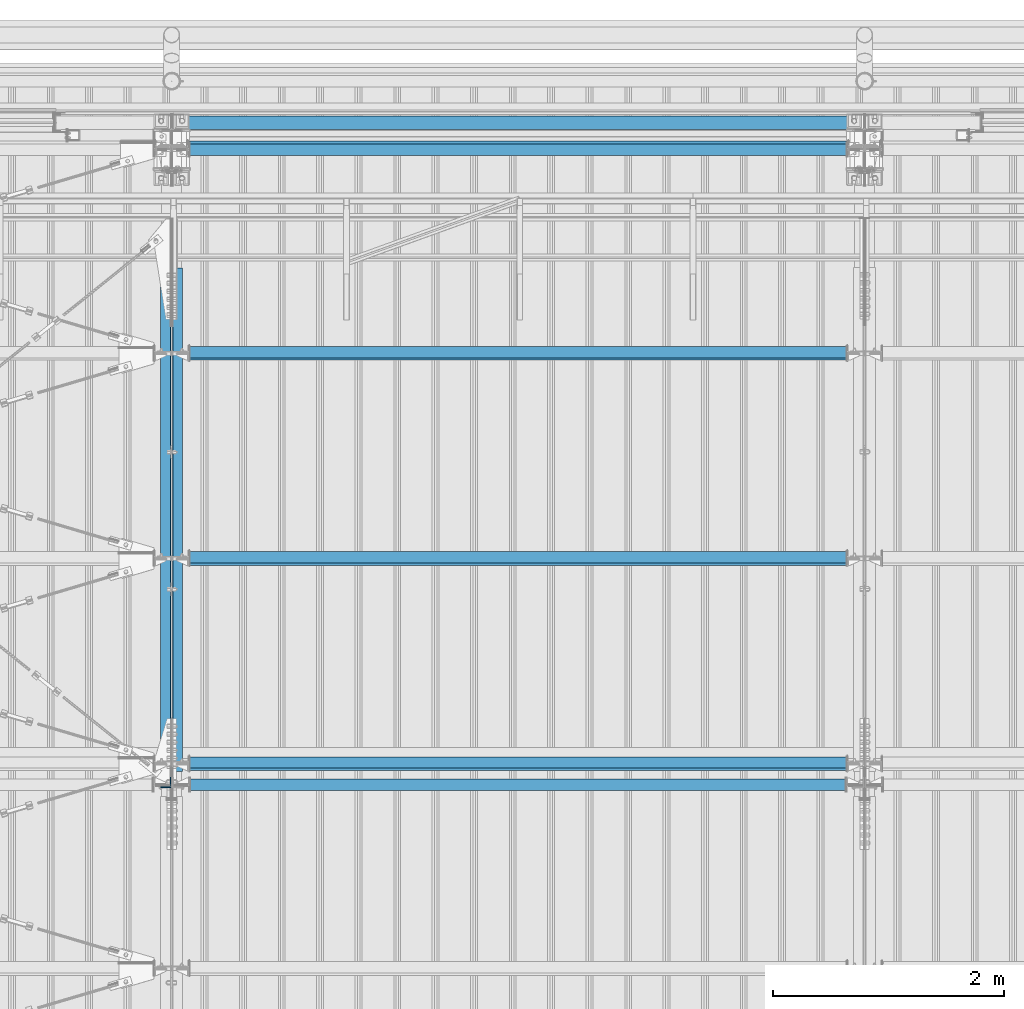
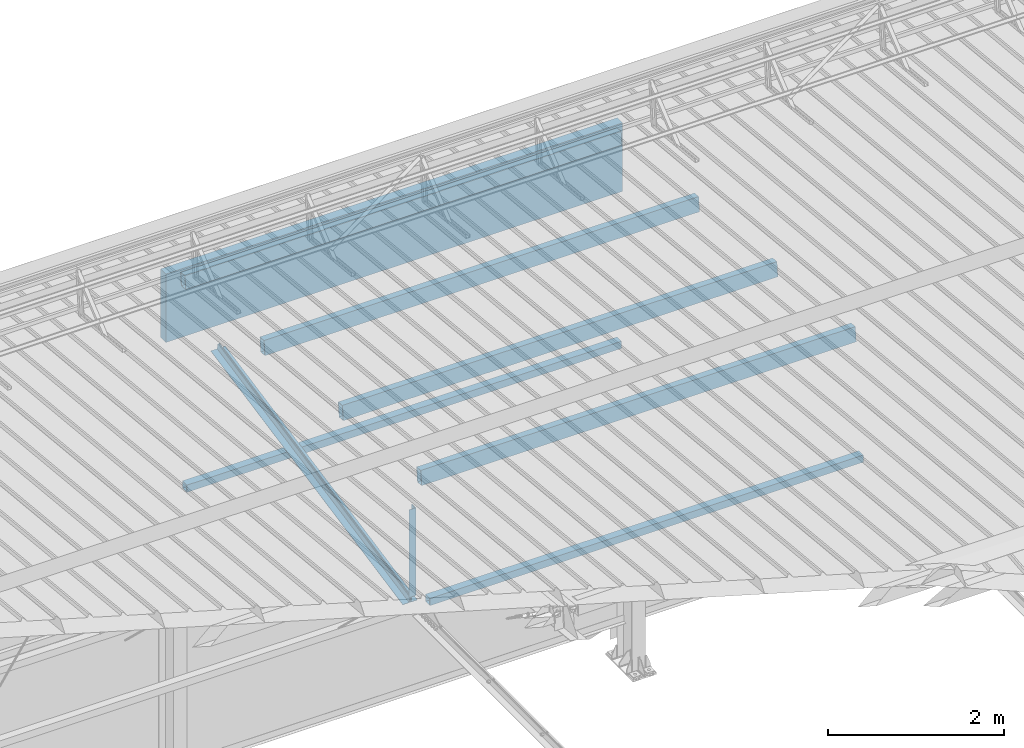
# One storey, part 266 of 709: 10 beams, 10 elements without a shape of their own.
"""IFC4 building model written with IfcOpenShell, lengths in millimetres."""

from ifc_helpers import new_model, si_unit, direction, frame, origin_with_axes, place, context, subcontext, project, spatial, polygons, material, element, aggregate, save


model = new_model("IFC4")

# Units and contexts
model_context = context("Model", 3, precision=0.2, world=origin_with_axes(), true_north=direction((0.0, 1.0)))
body_context = subcontext(model_context, "Body", "Model", "MODEL_VIEW")
ifc_project = project(units=[si_unit("LENGTHUNIT", "METRE", prefix="MILLI"), si_unit("AREAUNIT", "SQUARE_METRE"), si_unit("VOLUMEUNIT", "CUBIC_METRE"), si_unit("MASSUNIT", "GRAM", prefix="KILO"), si_unit("TIMEUNIT", "SECOND"), si_unit("PLANEANGLEUNIT", "RADIAN"), si_unit("SOLIDANGLEUNIT", "STERADIAN"), si_unit("THERMODYNAMICTEMPERATUREUNIT", "DEGREE_CELSIUS"), si_unit("LUMINOUSINTENSITYUNIT", "LUMEN")], contexts=[model_context])

# Site, building, storey
site_placement = place(None, origin_with_axes())
site = spatial("IfcSite", under=ifc_project, at=site_placement, CompositionType="ELEMENT")
building_placement = place(site_placement, origin_with_axes())
building = spatial("IfcBuilding", under=site, at=building_placement, Name="Undefined", CompositionType="ELEMENT")
storey_placement = place(building_placement, origin_with_axes())
storey = spatial("IfcBuildingStorey", under=building, at=storey_placement, Name="Undefined", CompositionType="ELEMENT", Elevation=0.0)

# Assembly, beam
assembly_1_placement = place(storey_placement, frame((10051.0, 21649.9404, 7109.99804), z_axis=(0.0, -0.1961161349, 0.9805806757), x_axis=(0.0, -0.9805806757, -0.1961161349)))
assembly_1 = element("IfcElementAssembly", 1, at=assembly_1_placement, inside=storey)
ifc_material_1 = material(Name="C345-5", Category="STEEL")
beam_1_placement = place(assembly_1_placement, origin_with_axes())
beam_1 = element("IfcBeam", 2, at=beam_1_placement, material=ifc_material_1, ObjectType="435", context=body_context, shape_type="Tessellation", body=[
    polygons([(873.96605, -45.0, -45.0), (873.96605, 45.0, -45.0), (5317.375, 45.0, -45.0), (5317.375, -45.0, -45.0), (873.96605, 45.0, -39.0), (5317.375, 45.0, -39.0), (873.96605, -39.0, -39.0), (5317.375, -39.0, -39.0), (873.96605, -39.0, 45.0), (5317.375, -39.0, 45.0), (873.96605, -45.0, 45.0), (5317.375, -45.0, 45.0)], [[[1, 2, 3, 4]], [[2, 5, 6, 3]], [[5, 7, 8, 6]], [[7, 9, 10, 8]], [[9, 11, 12, 10]], [[11, 1, 4, 12]], [[6, 8, 10, 12, 4, 3]], [[11, 9, 7, 5, 2, 1]]], closed=True),
])
aggregate(assembly_1, [beam_1])

assembly_2_placement = place(storey_placement, frame((9949.0, 16322.9404, 6044.59804), z_axis=(0.0, -0.1961161349, 0.9805806757), x_axis=(0.0, 0.9805806757, 0.1961161349)))
assembly_2 = element("IfcElementAssembly", 3, at=assembly_2_placement, inside=storey)
beam_2_placement = place(assembly_2_placement, origin_with_axes())
beam_2 = element("IfcBeam", 4, at=beam_2_placement, material=ifc_material_1, ObjectType="435", context=body_context, shape_type="Tessellation", body=[
    polygons([(115.12039, -45.0, -45.0), (115.12039, 45.0, -45.0), (4558.52934, 45.0, -45.0), (4558.52934, -45.0, -45.0), (115.12039, 45.0, -39.0), (4558.52934, 45.0, -39.0), (115.12039, -39.0, -39.0), (4558.52934, -39.0, -39.0), (115.12039, -39.0, 45.0), (4558.52934, -39.0, 45.0), (115.12039, -45.0, 45.0), (4558.52934, -45.0, 45.0)], [[[1, 2, 3, 4]], [[2, 5, 6, 3]], [[5, 7, 8, 6]], [[7, 9, 10, 8]], [[9, 11, 12, 10]], [[11, 1, 4, 12]], [[6, 8, 10, 12, 4, 3]], [[11, 9, 7, 5, 2, 1]]], closed=True),
])
aggregate(assembly_2, [beam_2])

assembly_3_placement = place(storey_placement, frame((9949.0, 16347.7, 7622.40002), z_axis=(0.0, 1.0, 0.0), x_axis=(0.0, 0.0, -1.0)))
assembly_3 = element("IfcElementAssembly", 5, at=assembly_3_placement, inside=storey)
beam_3_placement = place(assembly_3_placement, origin_with_axes())
beam_3 = element("IfcBeam", 6, at=beam_3_placement, material=ifc_material_1, ObjectType="436", context=body_context, shape_type="Tessellation", body=[
    polygons([(198.6891, -45.0, -45.0), (198.6891, 45.0, -45.0), (1412.4, 45.0, -45.0), (1412.4, -45.0, -45.0), (198.6891, 45.0, -39.0), (1412.4, 45.0, -39.0), (198.6891, -39.0, -39.0), (1412.4, -39.0, -39.0), (198.6891, -39.0, 45.0), (1412.4, -39.0, 45.0), (198.6891, -45.0, 45.0), (1412.4, -45.0, 45.0)], [[[1, 2, 3, 4]], [[2, 5, 6, 3]], [[5, 7, 8, 6]], [[7, 9, 10, 8]], [[9, 11, 12, 10]], [[11, 1, 4, 12]], [[6, 8, 10, 12, 4, 3]], [[11, 9, 7, 5, 2, 1]]], closed=True),
])
aggregate(assembly_3, [beam_3])

assembly_4_placement = place(storey_placement, frame((16000.0, 21827.0, 4310.0), z_axis=(0.0, 0.0, -1.0), x_axis=(-1.0, 0.0, 0.0)))
assembly_4 = element("IfcElementAssembly", 7, at=assembly_4_placement, inside=storey)
ifc_material_2 = material(Name="C355", Category="STEEL")
beam_4_placement = place(assembly_4_placement, origin_with_axes())
beam_4 = element("IfcBeam", 8, at=beam_4_placement, material=ifc_material_2, ObjectType="546", context=body_context, shape_type="Tessellation", body=[
    polygons([(155.0, -47.0, -47.0), (155.0, -47.0, 47.0), (5845.0, -47.0, 47.0), (5845.0, -47.0, -47.0), (155.0, 47.0, 47.0), (5845.0, 47.0, 47.0), (155.0, 47.0, -47.0), (5845.0, 47.0, -47.0), (155.0, -50.0, -50.0), (155.0, 50.0, -50.0), (5845.0, 50.0, -50.0), (5845.0, -50.0, -50.0), (155.0, 50.0, 50.0), (5845.0, 50.0, 50.0), (155.0, -50.0, 50.0), (5845.0, -50.0, 50.0)], [[[1, 2, 3, 4]], [[2, 5, 6, 3]], [[5, 7, 8, 6]], [[7, 1, 4, 8]], [[9, 10, 11, 12]], [[10, 13, 14, 11]], [[13, 15, 16, 14]], [[15, 9, 12, 16]], [[14, 16, 12, 11], [6, 8, 4, 3]], [[15, 13, 10, 9], [7, 5, 2, 1]]], closed=True),
])
aggregate(assembly_4, [beam_4])

assembly_5_placement = place(storey_placement, frame((10000.0, 16327.0, 6074.30002), z_axis=(0.0, -1.0, 0.0), x_axis=(1.0, 0.0, 0.0)))
assembly_5 = element("IfcElementAssembly", 9, at=assembly_5_placement, inside=storey)
beam_5_placement = place(assembly_5_placement, origin_with_axes())
beam_5 = element("IfcBeam", 10, at=beam_5_placement, material=ifc_material_2, ObjectType="557", context=body_context, shape_type="Tessellation", body=[
    polygons([(162.0, -47.0, -47.0), (162.0, -47.0, 47.0), (5838.0, -47.0, 47.0), (5838.0, -47.0, -47.0), (162.0, 47.0, 47.0), (5838.0, 47.0, 47.0), (162.0, 47.0, -47.0), (5838.0, 47.0, -47.0), (162.0, -50.0, -50.0), (162.0, 50.0, -50.0), (5838.0, 50.0, -50.0), (5838.0, -50.0, -50.0), (162.0, 50.0, 50.0), (5838.0, 50.0, 50.0), (162.0, -50.0, 50.0), (5838.0, -50.0, 50.0)], [[[1, 2, 3, 4]], [[2, 5, 6, 3]], [[5, 7, 8, 6]], [[7, 1, 4, 8]], [[9, 10, 11, 12]], [[10, 13, 14, 11]], [[13, 15, 16, 14]], [[15, 9, 12, 16]], [[14, 16, 12, 11], [6, 8, 4, 3]], [[15, 13, 10, 9], [7, 5, 2, 1]]], closed=True),
])
aggregate(assembly_5, [beam_5])

assembly_6_placement = place(storey_placement, frame((16000.0, 16509.95037, 7677.46908), z_axis=(0.0, -0.9950371902, 0.099503719), x_axis=(-1.0, 0.0, 0.0)))
assembly_6 = element("IfcElementAssembly", 11, at=assembly_6_placement, inside=storey)
beam_6_placement = place(assembly_6_placement, origin_with_axes())
beam_6 = element("IfcBeam", 12, at=beam_6_placement, material=ifc_material_2, ObjectType="579", context=body_context, shape_type="Tessellation", body=[
    polygons([(155.0, -96.0, -46.0), (155.0, -96.0, 46.0), (5845.0, -96.0, 46.0), (5845.0, -96.0, -46.0), (155.0, 96.0, 46.0), (5845.0, 96.0, 46.0), (155.0, 96.0, -46.0), (5845.0, 96.0, -46.0), (155.0, -100.0, -50.0), (155.0, 100.0, -50.0), (5845.0, 100.0, -50.0), (5845.0, -100.0, -50.0), (155.0, 100.0, 50.0), (5845.0, 100.0, 50.0), (155.0, -100.0, 50.0), (5845.0, -100.0, 50.0)], [[[1, 2, 3, 4]], [[2, 5, 6, 3]], [[5, 7, 8, 6]], [[7, 1, 4, 8]], [[9, 10, 11, 12]], [[10, 13, 14, 11]], [[13, 15, 16, 14]], [[15, 9, 12, 16]], [[14, 16, 12, 11], [6, 8, 4, 3]], [[15, 13, 10, 9], [7, 5, 2, 1]]], closed=True),
])
aggregate(assembly_6, [beam_6])

assembly_7_placement = place(storey_placement, frame((16000.0, 18286.65012, 7499.7991), z_axis=(0.0, -0.9950371902, 0.099503719), x_axis=(-1.0, 0.0, 0.0)))
assembly_7 = element("IfcElementAssembly", 13, at=assembly_7_placement, inside=storey)
beam_7_placement = place(assembly_7_placement, origin_with_axes())
beam_7 = element("IfcBeam", 14, at=beam_7_placement, material=ifc_material_2, ObjectType="579", context=body_context, shape_type="Tessellation", body=[
    polygons([(155.0, -96.0, -46.0), (155.0, -96.0, 46.0), (5845.0, -96.0, 46.0), (5845.0, -96.0, -46.0), (155.0, 96.0, 46.0), (5845.0, 96.0, 46.0), (155.0, 96.0, -46.0), (5845.0, 96.0, -46.0), (155.0, -100.0, -50.0), (155.0, 100.0, -50.0), (5845.0, 100.0, -50.0), (5845.0, -100.0, -50.0), (155.0, 100.0, 50.0), (5845.0, 100.0, 50.0), (155.0, -100.0, 50.0), (5845.0, -100.0, 50.0)], [[[1, 2, 3, 4]], [[2, 5, 6, 3]], [[5, 7, 8, 6]], [[7, 1, 4, 8]], [[9, 10, 11, 12]], [[10, 13, 14, 11]], [[13, 15, 16, 14]], [[15, 9, 12, 16]], [[14, 16, 12, 11], [6, 8, 4, 3]], [[15, 13, 10, 9], [7, 5, 2, 1]]], closed=True),
])
aggregate(assembly_7, [beam_7])

assembly_8_placement = place(storey_placement, frame((16000.0, 20063.34988, 7322.12913), z_axis=(0.0, -0.9950371902, 0.099503719), x_axis=(-1.0, 0.0, 0.0)))
assembly_8 = element("IfcElementAssembly", 15, at=assembly_8_placement, inside=storey)
beam_8_placement = place(assembly_8_placement, origin_with_axes())
beam_8 = element("IfcBeam", 16, at=beam_8_placement, material=ifc_material_2, ObjectType="579", context=body_context, shape_type="Tessellation", body=[
    polygons([(155.0, -96.0, -46.0), (155.0, -96.0, 46.0), (5845.0, -96.0, 46.0), (5845.0, -96.0, -46.0), (155.0, 96.0, 46.0), (5845.0, 96.0, 46.0), (155.0, 96.0, -46.0), (5845.0, 96.0, -46.0), (155.0, -100.0, -50.0), (155.0, 100.0, -50.0), (5845.0, 100.0, -50.0), (5845.0, -100.0, -50.0), (155.0, 100.0, 50.0), (5845.0, 100.0, 50.0), (155.0, -100.0, 50.0), (5845.0, -100.0, 50.0)], [[[1, 2, 3, 4]], [[2, 5, 6, 3]], [[5, 7, 8, 6]], [[7, 1, 4, 8]], [[9, 10, 11, 12]], [[10, 13, 14, 11]], [[13, 15, 16, 14]], [[15, 9, 12, 16]], [[14, 16, 12, 11], [6, 8, 4, 3]], [[15, 13, 10, 9], [7, 5, 2, 1]]], closed=True),
])
aggregate(assembly_8, [beam_8])

assembly_9_placement = place(storey_placement, frame((16000.0, 21841.04467, 7154.40952), z_axis=(0.0, -0.9950371902, 0.099503719), x_axis=(-1.0, 0.0, 0.0)))
assembly_9 = element("IfcElementAssembly", 17, at=assembly_9_placement, inside=storey)
beam_9_placement = place(assembly_9_placement, origin_with_axes())
beam_9 = element("IfcBeam", 18, at=beam_9_placement, material=ifc_material_2, ObjectType="578", context=body_context, shape_type="Tessellation", body=[
    polygons([(145.0, -86.0, -46.0), (145.0, -86.0, 46.0), (5855.0, -86.0, 46.0), (5855.0, -86.0, -46.0), (145.0, 86.0, 46.0), (5855.0, 86.0, 46.0), (145.0, 86.0, -46.0), (5855.0, 86.0, -46.0), (145.0, -90.0, -50.0), (145.0, 90.0, -50.0), (5855.0, 90.0, -50.0), (5855.0, -90.0, -50.0), (145.0, 90.0, 50.0), (5855.0, 90.0, 50.0), (145.0, -90.0, 50.0), (5855.0, -90.0, 50.0)], [[[1, 2, 3, 4]], [[2, 5, 6, 3]], [[5, 7, 8, 6]], [[7, 1, 4, 8]], [[9, 10, 11, 12]], [[10, 13, 14, 11]], [[13, 15, 16, 14]], [[15, 9, 12, 16]], [[14, 16, 12, 11], [6, 8, 4, 3]], [[15, 13, 10, 9], [7, 5, 2, 1]]], closed=True),
])
aggregate(assembly_9, [beam_9])

assembly_10_placement = place(storey_placement, frame((10010.0, 22060.0, 6845.0), z_axis=(0.0, 0.0, -1.0), x_axis=(1.0, 0.0, 0.0)))
assembly_10 = element("IfcElementAssembly", 19, at=assembly_10_placement, inside=storey)
ifc_material_3 = material(Name="Insulation", Category="Insulation")
beam_10_placement = place(assembly_10_placement, origin_with_axes())
beam_10 = element("IfcBeam", 20, at=beam_10_placement, material=ifc_material_3, ObjectType="P-108", context=body_context, shape_type="Tessellation", body=[
    polygons([(0.0, 60.0, 595.0), (0.0, -60.0, 595.0), (5980.0, -60.0, 595.0), (5980.0, 60.0, 595.0), (5980.0, 60.0, -351.923), (0.0, 60.0, -351.923), (0.0, -60.0, -351.923), (5980.0, -60.0, -351.923)], [[[1, 2, 3, 4]], [[1, 4, 5, 6]], [[2, 1, 6, 7]], [[3, 2, 7, 8]], [[4, 3, 8, 5]], [[7, 6, 5, 8]]], closed=True),
])
aggregate(assembly_10, [beam_10])

save(model, "model.ifc")
